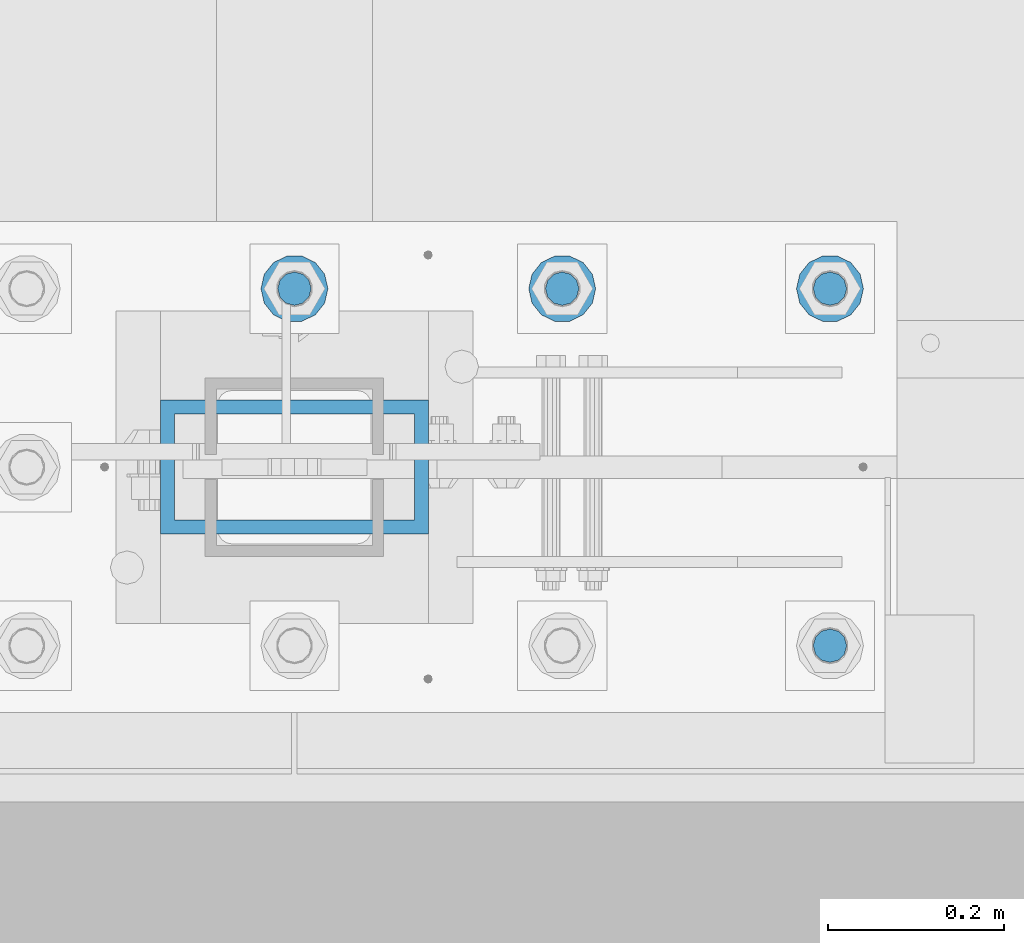
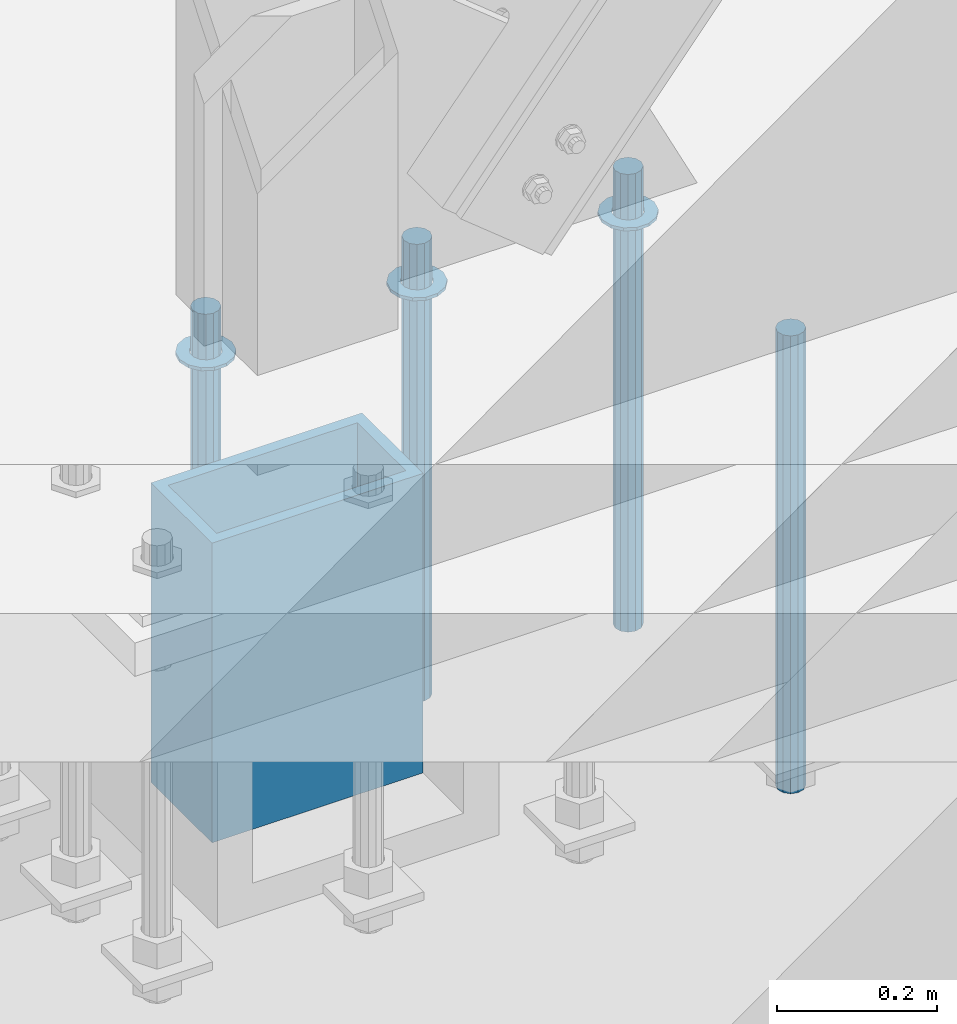
# One storey, part 932 of 1763: 8 columns, 2 elements without a shape of their own.
"""IFC2X3 building model written with IfcOpenShell, lengths in millimetres."""

from ifc_helpers import new_model, si_unit, frame, origin_with_axes, place, context, subcontext, project, spatial, faceted_brep, material, type_object, element, aggregate, save


model = new_model("IFC2X3")

# Units and contexts
model_context = context("Model", 3, precision=1e-05, world=origin_with_axes())
body_context = subcontext(model_context, "Body", "Model", "MODEL_VIEW")
ifc_project = project(units=[si_unit("LENGTHUNIT", "METRE", prefix="MILLI"), si_unit("AREAUNIT", "SQUARE_METRE"), si_unit("VOLUMEUNIT", "CUBIC_METRE"), si_unit("MASSUNIT", "GRAM", prefix="KILO"), si_unit("TIMEUNIT", "SECOND"), si_unit("PLANEANGLEUNIT", "RADIAN"), si_unit("SOLIDANGLEUNIT", "STERADIAN"), si_unit("THERMODYNAMICTEMPERATUREUNIT", "DEGREE_CELSIUS"), si_unit("LUMINOUSINTENSITYUNIT", "LUMEN")], contexts=[model_context])

# Site, building, storey
site_placement = place(None, origin_with_axes())
site = spatial("IfcSite", under=ifc_project, at=site_placement, CompositionType="ELEMENT")
building_placement = place(site_placement, origin_with_axes())
building = spatial("IfcBuilding", under=site, at=building_placement, Name="Undefined", CompositionType="ELEMENT")
storey_placement = place(building_placement, origin_with_axes())
storey = spatial("IfcBuildingStorey", under=building, at=storey_placement, Name="Undefined", CompositionType="ELEMENT", Elevation=0.0)

# Assembly, columns
assembly_1_placement = place(storey_placement, origin_with_axes())
assembly_1 = element("IfcElementAssembly", 1, at=assembly_1_placement, inside=storey, Name="TEMPLATE", AssemblyPlace="NOTDEFINED", PredefinedType="RIGID_FRAME")
ifc_material_1 = material(Name="STEEL/F436")
column_type_1 = type_object("IfcColumnType", Name="1-1/2_WASHER", PredefinedType="NOTDEFINED")
column_1_placement = place(assembly_1_placement, frame((-34949.8372736984, -13512.8, 5151.4375), z_axis=(0.0, -1.0, 0.0), x_axis=(0.0, 0.0, -1.0)))
column_1 = element("IfcColumn", 2, at=column_1_placement, type_object=column_type_1, material=ifc_material_1, Name="WASHER", ObjectType="1-1/2_WASHER", context=body_context, shape_type="Brep", body=[
    faceted_brep([(0.0, -38.0999984741211, 0.0), (0.0, -34.3269124923099, -16.5309697983248), (4.76249999999982, -34.3269124923099, -16.5309697983248), (4.76249999999982, -38.0999984741211, 0.0), (0.0, -23.7549604994492, -29.7877782890519), (4.76249999999982, -23.7549604994492, -29.7877782890519), (0.0, -8.47804724419257, -37.1447519665053), (4.76249999999982, -8.47804724419257, -37.1447519665053), (0.0, 8.47804724419257, -37.1447519665053), (4.76249999999982, 8.47804724419257, -37.1447519665053), (0.0, 23.7549604994492, -29.7877782890519), (4.76249999999982, 23.7549604994492, -29.7877782890519), (0.0, 34.3269124923099, -16.5309697983248), (4.76249999999982, 34.3269124923099, -16.5309697983248), (0.0, 38.0999984741211, 0.0), (4.76249999999982, 38.0999984741211, 0.0), (0.0, 34.3269124923099, 16.5309697983248), (4.76249999999982, 34.3269124923099, 16.5309697983248), (0.0, 23.7549604994492, 29.7877782890519), (4.76249999999982, 23.7549604994492, 29.7877782890519), (0.0, 8.47804724419257, 37.1447519665053), (4.76249999999982, 8.47804724419257, 37.1447519665053), (0.0, -8.47804724419257, 37.1447519665053), (4.76249999999982, -8.47804724419257, 37.1447519665053), (0.0, -23.7549604994492, 29.7877782890519), (4.76249999999982, -23.7549604994492, 29.7877782890519), (0.0, -34.3269124923099, 16.5309697983248), (4.76249999999982, -34.3269124923099, 16.5309697983248), (0.0, 0.0, 20.6399993896484), (0.0, 8.95536011056538, 18.5959968835978), (4.76249999999982, 8.95536011056538, 18.5959968835978), (4.76249999999982, 0.0, 20.6399993896484), (0.0, 16.1370013209453, 12.8688291298167), (4.76249999999982, 16.1370013209453, 12.8688291298167), (0.0, 20.1225115123816, 4.59283194104137), (4.76249999999982, 20.1225115123816, 4.59283194104137), (0.0, 20.1225115123816, -4.59283194104319), (4.76249999999982, 20.1225115123816, -4.59283194104319), (0.0, 16.1370013209453, -12.8688291298167), (4.76249999999982, 16.1370013209453, -12.8688291298167), (0.0, 8.95536011056538, -18.5959968835978), (4.76249999999982, 8.95536011056538, -18.5959968835978), (0.0, 0.0, -20.6399993896484), (4.76249999999982, 0.0, -20.6399993896484), (0.0, -8.95536011056538, -18.5959968835978), (4.76249999999982, -8.95536011056538, -18.5959968835978), (0.0, -16.1370013209453, -12.8688291298167), (4.76249999999982, -16.1370013209453, -12.8688291298167), (0.0, -20.1225115123816, -4.59283194104137), (4.76249999999982, -20.1225115123816, -4.59283194104137), (0.0, -20.1225115123816, 4.59283194104319), (4.76249999999982, -20.1225115123816, 4.59283194104319), (0.0, -16.1370013209453, 12.8688291298167), (4.76249999999982, -16.1370013209453, 12.8688291298167), (0.0, -8.95536011056538, 18.5959968835978), (4.76249999999982, -8.95536011056538, 18.5959968835978)], [[[0, 1, 2, 3]], [[1, 4, 5, 2]], [[4, 6, 7, 5]], [[6, 8, 9, 7]], [[8, 10, 11, 9]], [[10, 12, 13, 11]], [[12, 14, 15, 13]], [[14, 16, 17, 15]], [[16, 18, 19, 17]], [[18, 20, 21, 19]], [[20, 22, 23, 21]], [[22, 24, 25, 23]], [[24, 26, 27, 25]], [[26, 0, 3, 27]], [[28, 29, 30, 31]], [[29, 32, 33, 30]], [[32, 34, 35, 33]], [[34, 36, 37, 35]], [[36, 38, 39, 37]], [[38, 40, 41, 39]], [[40, 42, 43, 41]], [[42, 44, 45, 43]], [[44, 46, 47, 45]], [[46, 48, 49, 47]], [[48, 50, 51, 49]], [[50, 52, 53, 51]], [[52, 54, 55, 53]], [[54, 28, 31, 55]], [[5, 7, 9, 11, 13, 15, 17, 19, 21, 23, 25, 27, 3, 2], [33, 35, 37, 39, 41, 43, 45, 47, 49, 51, 53, 55, 31, 30]], [[26, 24, 22, 20, 18, 16, 14, 12, 10, 8, 6, 4, 1, 0], [54, 52, 50, 48, 46, 44, 42, 40, 38, 36, 34, 32, 29, 28]]]),
])
column_2_placement = place(assembly_1_placement, frame((-34645.0372736983, -13512.8, 5151.4375), z_axis=(0.0, 1.0, 0.0), x_axis=(0.0, 0.0, -1.0)))
column_2 = element("IfcColumn", 3, at=column_2_placement, type_object=column_type_1, material=ifc_material_1, Name="WASHER", ObjectType="1-1/2_WASHER", context=body_context, shape_type="Brep", body=[
    faceted_brep([(0.0, -38.0999984741211, 0.0), (0.0, -34.3269124923099, -16.5309697983248), (4.76249999999982, -34.3269124923099, -16.5309697983248), (4.76249999999982, -38.0999984741211, 0.0), (0.0, -23.7549604994492, -29.7877782890519), (4.76249999999982, -23.7549604994492, -29.7877782890519), (0.0, -8.47804724419257, -37.1447519665053), (4.76249999999982, -8.47804724419257, -37.1447519665053), (0.0, 8.47804724419257, -37.1447519665053), (4.76249999999982, 8.47804724419257, -37.1447519665053), (0.0, 23.7549604994492, -29.7877782890519), (4.76249999999982, 23.7549604994492, -29.7877782890519), (0.0, 34.3269124923099, -16.5309697983248), (4.76249999999982, 34.3269124923099, -16.5309697983248), (0.0, 38.0999984741211, 0.0), (4.76249999999982, 38.0999984741211, 0.0), (0.0, 34.3269124923099, 16.5309697983248), (4.76249999999982, 34.3269124923099, 16.5309697983248), (0.0, 23.7549604994492, 29.7877782890519), (4.76249999999982, 23.7549604994492, 29.7877782890519), (0.0, 8.47804724419257, 37.1447519665053), (4.76249999999982, 8.47804724419257, 37.1447519665053), (0.0, -8.47804724419257, 37.1447519665053), (4.76249999999982, -8.47804724419257, 37.1447519665053), (0.0, -23.7549604994492, 29.7877782890519), (4.76249999999982, -23.7549604994492, 29.7877782890519), (0.0, -34.3269124923099, 16.5309697983248), (4.76249999999982, -34.3269124923099, 16.5309697983248), (0.0, 0.0, 20.6399993896484), (0.0, 8.95536011056538, 18.5959968835978), (4.76249999999982, 8.95536011056538, 18.5959968835978), (4.76249999999982, 0.0, 20.6399993896484), (0.0, 16.1370013209453, 12.8688291298167), (4.76249999999982, 16.1370013209453, 12.8688291298167), (0.0, 20.1225115123816, 4.59283194104137), (4.76249999999982, 20.1225115123816, 4.59283194104137), (0.0, 20.1225115123816, -4.59283194104319), (4.76249999999982, 20.1225115123816, -4.59283194104319), (0.0, 16.1370013209453, -12.8688291298167), (4.76249999999982, 16.1370013209453, -12.8688291298167), (0.0, 8.95536011056538, -18.5959968835978), (4.76249999999982, 8.95536011056538, -18.5959968835978), (0.0, 0.0, -20.6399993896484), (4.76249999999982, 0.0, -20.6399993896484), (0.0, -8.95536011056538, -18.5959968835978), (4.76249999999982, -8.95536011056538, -18.5959968835978), (0.0, -16.1370013209453, -12.8688291298167), (4.76249999999982, -16.1370013209453, -12.8688291298167), (0.0, -20.1225115123816, -4.59283194104137), (4.76249999999982, -20.1225115123816, -4.59283194104137), (0.0, -20.1225115123816, 4.59283194104319), (4.76249999999982, -20.1225115123816, 4.59283194104319), (0.0, -16.1370013209453, 12.8688291298167), (4.76249999999982, -16.1370013209453, 12.8688291298167), (0.0, -8.95536011056538, 18.5959968835978), (4.76249999999982, -8.95536011056538, 18.5959968835978)], [[[0, 1, 2, 3]], [[1, 4, 5, 2]], [[4, 6, 7, 5]], [[6, 8, 9, 7]], [[8, 10, 11, 9]], [[10, 12, 13, 11]], [[12, 14, 15, 13]], [[14, 16, 17, 15]], [[16, 18, 19, 17]], [[18, 20, 21, 19]], [[20, 22, 23, 21]], [[22, 24, 25, 23]], [[24, 26, 27, 25]], [[26, 0, 3, 27]], [[28, 29, 30, 31]], [[29, 32, 33, 30]], [[32, 34, 35, 33]], [[34, 36, 37, 35]], [[36, 38, 39, 37]], [[38, 40, 41, 39]], [[40, 42, 43, 41]], [[42, 44, 45, 43]], [[44, 46, 47, 45]], [[46, 48, 49, 47]], [[48, 50, 51, 49]], [[50, 52, 53, 51]], [[52, 54, 55, 53]], [[54, 28, 31, 55]], [[5, 7, 9, 11, 13, 15, 17, 19, 21, 23, 25, 27, 3, 2], [33, 35, 37, 39, 41, 43, 45, 47, 49, 51, 53, 55, 31, 30]], [[26, 24, 22, 20, 18, 16, 14, 12, 10, 8, 6, 4, 1, 0], [54, 52, 50, 48, 46, 44, 42, 40, 38, 36, 34, 32, 29, 28]]]),
])
column_3_placement = place(assembly_1_placement, frame((-34340.2372736983, -13512.8, 5151.4375), z_axis=(0.0, 1.0, 0.0), x_axis=(0.0, 0.0, -1.0)))
column_3 = element("IfcColumn", 4, at=column_3_placement, type_object=column_type_1, material=ifc_material_1, Name="WASHER", ObjectType="1-1/2_WASHER", context=body_context, shape_type="Brep", body=[
    faceted_brep([(0.0, -38.0999984741211, 0.0), (0.0, -34.3269124923099, -16.5309697983248), (4.76249999999982, -34.3269124923099, -16.5309697983248), (4.76249999999982, -38.0999984741211, 0.0), (0.0, -23.7549604994492, -29.7877782890519), (4.76249999999982, -23.7549604994492, -29.7877782890519), (0.0, -8.47804724419257, -37.1447519665053), (4.76249999999982, -8.47804724419257, -37.1447519665053), (0.0, 8.47804724419257, -37.1447519665053), (4.76249999999982, 8.47804724419257, -37.1447519665053), (0.0, 23.7549604994492, -29.7877782890519), (4.76249999999982, 23.7549604994492, -29.7877782890519), (0.0, 34.3269124923099, -16.5309697983248), (4.76249999999982, 34.3269124923099, -16.5309697983248), (0.0, 38.0999984741211, 0.0), (4.76249999999982, 38.0999984741211, 0.0), (0.0, 34.3269124923099, 16.5309697983248), (4.76249999999982, 34.3269124923099, 16.5309697983248), (0.0, 23.7549604994492, 29.7877782890519), (4.76249999999982, 23.7549604994492, 29.7877782890519), (0.0, 8.47804724419257, 37.1447519665053), (4.76249999999982, 8.47804724419257, 37.1447519665053), (0.0, -8.47804724419257, 37.1447519665053), (4.76249999999982, -8.47804724419257, 37.1447519665053), (0.0, -23.7549604994492, 29.7877782890519), (4.76249999999982, -23.7549604994492, 29.7877782890519), (0.0, -34.3269124923099, 16.5309697983248), (4.76249999999982, -34.3269124923099, 16.5309697983248), (0.0, 0.0, 20.6399993896484), (0.0, 8.95536011056538, 18.5959968835978), (4.76249999999982, 8.95536011056538, 18.5959968835978), (4.76249999999982, 0.0, 20.6399993896484), (0.0, 16.1370013209453, 12.8688291298167), (4.76249999999982, 16.1370013209453, 12.8688291298167), (0.0, 20.1225115123816, 4.59283194104137), (4.76249999999982, 20.1225115123816, 4.59283194104137), (0.0, 20.1225115123816, -4.59283194104319), (4.76249999999982, 20.1225115123816, -4.59283194104319), (0.0, 16.1370013209453, -12.8688291298167), (4.76249999999982, 16.1370013209453, -12.8688291298167), (0.0, 8.95536011056538, -18.5959968835978), (4.76249999999982, 8.95536011056538, -18.5959968835978), (0.0, 0.0, -20.6399993896484), (4.76249999999982, 0.0, -20.6399993896484), (0.0, -8.95536011056538, -18.5959968835978), (4.76249999999982, -8.95536011056538, -18.5959968835978), (0.0, -16.1370013209453, -12.8688291298167), (4.76249999999982, -16.1370013209453, -12.8688291298167), (0.0, -20.1225115123816, -4.59283194104137), (4.76249999999982, -20.1225115123816, -4.59283194104137), (0.0, -20.1225115123816, 4.59283194104319), (4.76249999999982, -20.1225115123816, 4.59283194104319), (0.0, -16.1370013209453, 12.8688291298167), (4.76249999999982, -16.1370013209453, 12.8688291298167), (0.0, -8.95536011056538, 18.5959968835978), (4.76249999999982, -8.95536011056538, 18.5959968835978)], [[[0, 1, 2, 3]], [[1, 4, 5, 2]], [[4, 6, 7, 5]], [[6, 8, 9, 7]], [[8, 10, 11, 9]], [[10, 12, 13, 11]], [[12, 14, 15, 13]], [[14, 16, 17, 15]], [[16, 18, 19, 17]], [[18, 20, 21, 19]], [[20, 22, 23, 21]], [[22, 24, 25, 23]], [[24, 26, 27, 25]], [[26, 0, 3, 27]], [[28, 29, 30, 31]], [[29, 32, 33, 30]], [[32, 34, 35, 33]], [[34, 36, 37, 35]], [[36, 38, 39, 37]], [[38, 40, 41, 39]], [[40, 42, 43, 41]], [[42, 44, 45, 43]], [[44, 46, 47, 45]], [[46, 48, 49, 47]], [[48, 50, 51, 49]], [[50, 52, 53, 51]], [[52, 54, 55, 53]], [[54, 28, 31, 55]], [[5, 7, 9, 11, 13, 15, 17, 19, 21, 23, 25, 27, 3, 2], [33, 35, 37, 39, 41, 43, 45, 47, 49, 51, 53, 55, 31, 30]], [[26, 24, 22, 20, 18, 16, 14, 12, 10, 8, 6, 4, 1, 0], [54, 52, 50, 48, 46, 44, 42, 40, 38, 36, 34, 32, 29, 28]]]),
])
ifc_material_2 = material(Name="STEEL/F1554-GR.55")
column_type_2 = type_object("IfcColumnType", PredefinedType="NOTDEFINED")
column_4_placement = place(assembly_1_placement, frame((-34340.2372736983, -13919.2, 5219.7), z_axis=(0.0, 1.0, 0.0), x_axis=(0.0, 0.0, -1.0)))
column_4 = element("IfcColumn", 5, at=column_4_placement, type_object=column_type_2, material=ifc_material_2, Name="ALL THREADED ROD", context=body_context, shape_type="Brep", body=[
    faceted_brep([(0.0, -19.0500000000029, 0.0), (0.0, -16.4977839420899, -9.52500000000146), (698.499, -16.4977839420972, -9.52499999999964), (698.499, -19.0500000000029, 0.0), (0.0, -9.52499999999418, -16.4977839420935), (698.499, -9.52500000000146, -16.4977839420935), (1.45519152283669e-11, 1.81898940354586e-12, -19.0499999999993), (698.499, 0.0, -19.0499999999993), (0.0, 9.52499999999418, -16.4977839420935), (698.499, 9.52500000000146, -16.4977839420935), (0.0, 16.4977839420899, -9.52500000000146), (698.499, 16.4977839420972, -9.52499999999964), (0.0, 19.0500000000029, 0.0), (698.499, 19.0500000000029, 0.0), (0.0, 16.4977839420899, 9.52500000000146), (698.499, 16.4977839420972, 9.52499999999964), (0.0, 9.52499999999418, 16.4977839420935), (698.499, 9.52500000000146, 16.4977839420935), (1.45519152283669e-11, 1.81898940354586e-12, 19.0499999999993), (698.499, 0.0, 19.0499999999993), (0.0, -9.52499999999418, 16.4977839420935), (698.499, -9.52500000000146, 16.4977839420935), (0.0, -16.4977839420899, 9.52500000000146), (698.499, -16.4977839420972, 9.52499999999964)], [[[0, 1, 2, 3]], [[1, 4, 5, 2]], [[4, 6, 7, 5]], [[6, 8, 9, 7]], [[8, 10, 11, 9]], [[10, 12, 13, 11]], [[12, 14, 15, 13]], [[14, 16, 17, 15]], [[16, 18, 19, 17]], [[18, 20, 21, 19]], [[20, 22, 23, 21]], [[22, 0, 3, 23]], [[5, 7, 9, 11, 13, 15, 17, 19, 21, 23, 3, 2]], [[22, 20, 18, 16, 14, 12, 10, 8, 6, 4, 1, 0]]]),
])
column_5_placement = place(assembly_1_placement, frame((-34949.8372736984, -13512.8, 5219.7), z_axis=(0.0, -1.0, 0.0), x_axis=(0.0, 0.0, -1.0)))
column_5 = element("IfcColumn", 6, at=column_5_placement, type_object=column_type_2, material=ifc_material_2, Name="ALL THREADED ROD", context=body_context, shape_type="Brep", body=[
    faceted_brep([(0.0, -19.0500000000029, 0.0), (0.0, -16.4977839420899, -9.52500000000146), (698.499, -16.4977839420972, -9.52499999999964), (698.499, -19.0500000000029, 0.0), (0.0, -9.52499999999418, -16.4977839420935), (698.499, -9.52500000000146, -16.4977839420935), (1.45519152283669e-11, 1.81898940354586e-12, -19.0499999999993), (698.499, 0.0, -19.0499999999993), (0.0, 9.52499999999418, -16.4977839420935), (698.499, 9.52500000000146, -16.4977839420935), (0.0, 16.4977839420899, -9.52500000000146), (698.499, 16.4977839420972, -9.52499999999964), (0.0, 19.0500000000029, 0.0), (698.499, 19.0500000000029, 0.0), (0.0, 16.4977839420899, 9.52500000000146), (698.499, 16.4977839420972, 9.52499999999964), (0.0, 9.52499999999418, 16.4977839420935), (698.499, 9.52500000000146, 16.4977839420935), (1.45519152283669e-11, 1.81898940354586e-12, 19.0499999999993), (698.499, 0.0, 19.0499999999993), (0.0, -9.52499999999418, 16.4977839420935), (698.499, -9.52500000000146, 16.4977839420935), (0.0, -16.4977839420899, 9.52500000000146), (698.499, -16.4977839420972, 9.52499999999964)], [[[0, 1, 2, 3]], [[1, 4, 5, 2]], [[4, 6, 7, 5]], [[6, 8, 9, 7]], [[8, 10, 11, 9]], [[10, 12, 13, 11]], [[12, 14, 15, 13]], [[14, 16, 17, 15]], [[16, 18, 19, 17]], [[18, 20, 21, 19]], [[20, 22, 23, 21]], [[22, 0, 3, 23]], [[5, 7, 9, 11, 13, 15, 17, 19, 21, 23, 3, 2]], [[22, 20, 18, 16, 14, 12, 10, 8, 6, 4, 1, 0]]]),
])
column_6_placement = place(assembly_1_placement, frame((-34645.0372736983, -13512.8, 5219.7), z_axis=(0.0, 1.0, 0.0), x_axis=(0.0, 0.0, -1.0)))
column_6 = element("IfcColumn", 7, at=column_6_placement, type_object=column_type_2, material=ifc_material_2, Name="ALL THREADED ROD", context=body_context, shape_type="Brep", body=[
    faceted_brep([(0.0, -19.0500000000029, 0.0), (0.0, -16.4977839420899, -9.52500000000146), (698.499, -16.4977839420972, -9.52499999999964), (698.499, -19.0500000000029, 0.0), (0.0, -9.52499999999418, -16.4977839420935), (698.499, -9.52500000000146, -16.4977839420935), (1.45519152283669e-11, 1.81898940354586e-12, -19.0499999999993), (698.499, 0.0, -19.0499999999993), (0.0, 9.52499999999418, -16.4977839420935), (698.499, 9.52500000000146, -16.4977839420935), (0.0, 16.4977839420899, -9.52500000000146), (698.499, 16.4977839420972, -9.52499999999964), (0.0, 19.0500000000029, 0.0), (698.499, 19.0500000000029, 0.0), (0.0, 16.4977839420899, 9.52500000000146), (698.499, 16.4977839420972, 9.52499999999964), (0.0, 9.52499999999418, 16.4977839420935), (698.499, 9.52500000000146, 16.4977839420935), (1.45519152283669e-11, 1.81898940354586e-12, 19.0499999999993), (698.499, 0.0, 19.0499999999993), (0.0, -9.52499999999418, 16.4977839420935), (698.499, -9.52500000000146, 16.4977839420935), (0.0, -16.4977839420899, 9.52500000000146), (698.499, -16.4977839420972, 9.52499999999964)], [[[0, 1, 2, 3]], [[1, 4, 5, 2]], [[4, 6, 7, 5]], [[6, 8, 9, 7]], [[8, 10, 11, 9]], [[10, 12, 13, 11]], [[12, 14, 15, 13]], [[14, 16, 17, 15]], [[16, 18, 19, 17]], [[18, 20, 21, 19]], [[20, 22, 23, 21]], [[22, 0, 3, 23]], [[5, 7, 9, 11, 13, 15, 17, 19, 21, 23, 3, 2]], [[22, 20, 18, 16, 14, 12, 10, 8, 6, 4, 1, 0]]]),
])
column_7_placement = place(assembly_1_placement, frame((-34340.2372736983, -13512.8, 5219.7), z_axis=(0.0, 1.0, 0.0), x_axis=(0.0, 0.0, -1.0)))
column_7 = element("IfcColumn", 8, at=column_7_placement, type_object=column_type_2, material=ifc_material_2, Name="ALL THREADED ROD", context=body_context, shape_type="Brep", body=[
    faceted_brep([(0.0, -19.0500000000029, 0.0), (0.0, -16.4977839420899, -9.52500000000146), (698.499, -16.4977839420972, -9.52499999999964), (698.499, -19.0500000000029, 0.0), (0.0, -9.52499999999418, -16.4977839420935), (698.499, -9.52500000000146, -16.4977839420935), (1.45519152283669e-11, 1.81898940354586e-12, -19.0499999999993), (698.499, 0.0, -19.0499999999993), (0.0, 9.52499999999418, -16.4977839420935), (698.499, 9.52500000000146, -16.4977839420935), (0.0, 16.4977839420899, -9.52500000000146), (698.499, 16.4977839420972, -9.52499999999964), (0.0, 19.0500000000029, 0.0), (698.499, 19.0500000000029, 0.0), (0.0, 16.4977839420899, 9.52500000000146), (698.499, 16.4977839420972, 9.52499999999964), (0.0, 9.52499999999418, 16.4977839420935), (698.499, 9.52500000000146, 16.4977839420935), (1.45519152283669e-11, 1.81898940354586e-12, 19.0499999999993), (698.499, 0.0, 19.0499999999993), (0.0, -9.52499999999418, 16.4977839420935), (698.499, -9.52500000000146, 16.4977839420935), (0.0, -16.4977839420899, 9.52500000000146), (698.499, -16.4977839420972, 9.52499999999964)], [[[0, 1, 2, 3]], [[1, 4, 5, 2]], [[4, 6, 7, 5]], [[6, 8, 9, 7]], [[8, 10, 11, 9]], [[10, 12, 13, 11]], [[12, 14, 15, 13]], [[14, 16, 17, 15]], [[16, 18, 19, 17]], [[18, 20, 21, 19]], [[20, 22, 23, 21]], [[22, 0, 3, 23]], [[5, 7, 9, 11, 13, 15, 17, 19, 21, 23, 3, 2]], [[22, 20, 18, 16, 14, 12, 10, 8, 6, 4, 1, 0]]]),
])
aggregate(assembly_1, [column_4, column_1, column_5, column_2, column_6, column_3, column_7])

# Assembly, column
assembly_2_placement = place(storey_placement, origin_with_axes())
assembly_2 = element("IfcElementAssembly", 9, at=assembly_2_placement, inside=storey, Name="COLUMN", AssemblyPlace="NOTDEFINED", PredefinedType="RIGID_FRAME")
ifc_material_3 = material()
column_type_3 = type_object("IfcColumnType", Name="HSS12X6X5/8", PredefinedType="NOTDEFINED")
column_8_placement = place(assembly_2_placement, frame((-34949.8372736984, -13716.0, 4622.8), z_axis=(-1.0, 0.0, 0.0), x_axis=(0.0, 0.0, 1.0)))
column_8 = element("IfcColumn", 10, at=column_8_placement, type_object=column_type_3, material=ifc_material_3, Name="SHEAR", ObjectType="HSS12X6X5/8", context=body_context, shape_type="Brep", body=[
    faceted_brep([(0.0, 60.3250000000007, -136.524999999994), (0.0, -60.3250000000007, -136.524999999994), (457.2, -60.3250000000007, -136.524999999994), (457.2, 60.3250000000007, -136.524999999994), (0.0, -60.3250000000007, 136.524999999994), (457.2, -60.3250000000007, 136.524999999994), (0.0, 60.3250000000007, 136.524999999994), (457.2, 60.3250000000007, 136.524999999994), (0.0, 76.2000000000007, -152.399999999994), (0.0, 76.2000000000007, 152.399999999994), (457.2, 76.2000000000007, 152.399999999994), (457.2, 76.2000000000007, -152.399999999994), (0.0, -76.2000000000007, 152.399999999994), (457.2, -76.2000000000007, 152.399999999994), (0.0, -76.2000000000007, -152.399999999994), (457.2, -76.2000000000007, -152.399999999994)], [[[0, 1, 2, 3]], [[1, 4, 5, 2]], [[4, 6, 7, 5]], [[6, 0, 3, 7]], [[8, 9, 10, 11]], [[9, 12, 13, 10]], [[12, 14, 15, 13]], [[14, 8, 11, 15]], [[13, 15, 11, 10], [5, 7, 3, 2]], [[14, 12, 9, 8], [6, 4, 1, 0]]]),
])
aggregate(assembly_2, [column_8])

save(model, "model.ifc")
